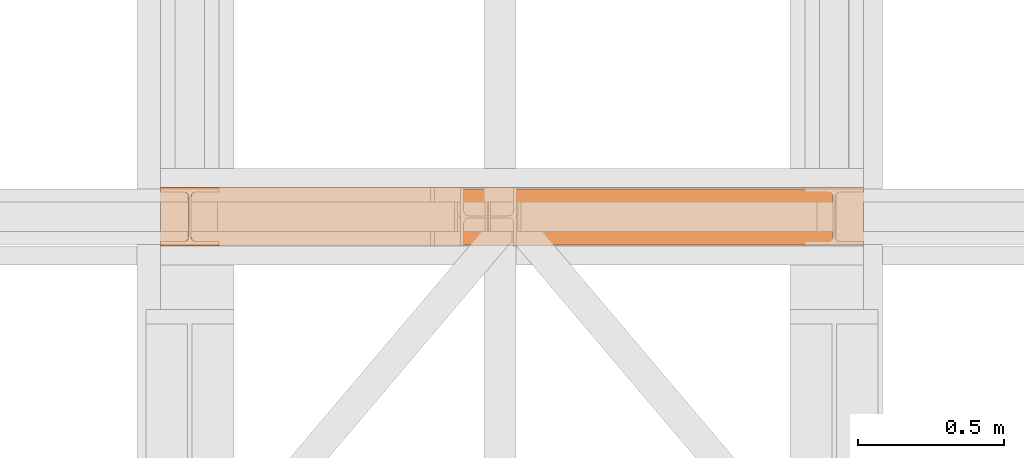
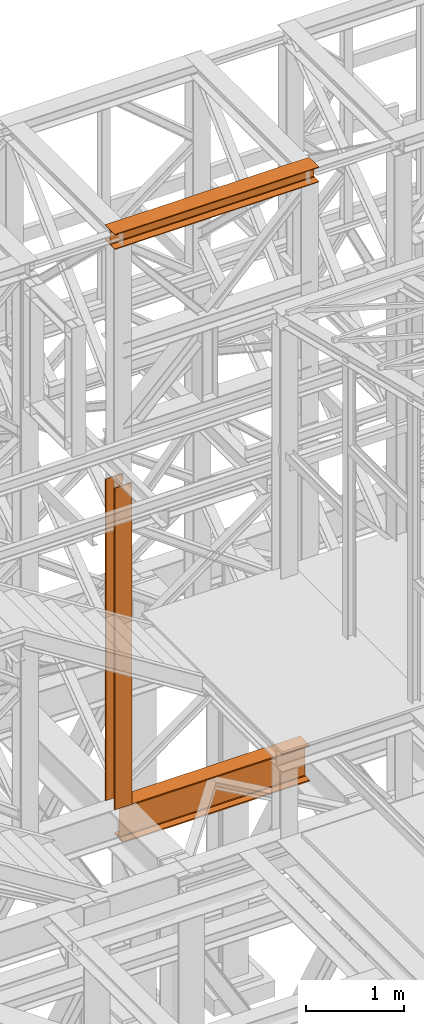
# One storey, part 108 of 208: 3 proxies.
"""IFC2X3 building model written with IfcOpenShell, lengths in millimetres."""

from ifc_helpers import new_model, entity, si_unit, converted_unit, frame, origin, origin_with_axes, place, context, subcontext, project, spatial, faceted_brep, element, save


model = new_model("IFC2X3")

# Units and contexts
model_context = context("Model", 3, precision=1e-05, world=origin())
plan_context = context("Plan", 3, precision=1e-05, world=origin())
body_context = subcontext(model_context, "Body", "Model", "MODEL_VIEW")
ifc_project = project(units=[si_unit("LENGTHUNIT", "METRE", prefix="MILLI"), converted_unit("PLANEANGLEUNIT", "DEGREE", entity("IfcPlaneAngleMeasure", 0.0174532925199433), si_unit("PLANEANGLEUNIT", "RADIAN"), dimensions=[0, 0, 0, 0, 0, 0, 0]), si_unit("AREAUNIT", "SQUARE_METRE"), si_unit("VOLUMEUNIT", "CUBIC_METRE")], contexts=[model_context, plan_context])

# Building, storey
building_placement = place(None, origin())
building = spatial("IfcBuilding", under=ifc_project, at=building_placement, CompositionType="COMPLEX")
storey_placement = place(building_placement, origin_with_axes())
storey = spatial("IfcBuildingStorey", under=building, at=storey_placement, Name="Geschoss", CompositionType="ELEMENT")

# Proxies
proxy_1_placement = place(storey_placement, frame((-0.7450314191753478, -16057.57439657637, 4834.989987483023), z_axis=(0.0, 0.0, 1.0), x_axis=(1.0, 0.0, 0.0)))
element("IfcBuildingElementProxy", 1, at=proxy_1_placement, inside=storey, context=body_context, shape_type="Brep", body=[
    faceted_brep([(2188.009999895692, 0.01000000000021828, 450.0100178813937), (2188.009999895692, 190.0100125169756, 450.0100178813937), (2188.009999895692, 190.0100125169756, 435.4100240564349), (2188.009999895692, 120.7100073045494, 435.4100091552737), (2188.009999895692, 109.841562265754, 433.2347078418734), (2188.009999895692, 101.8853126263621, 425.2784563398363), (2188.009999895692, 99.71000619068764, 414.4100113010409), (2188.009999895692, 99.71000619068764, 35.60999167919181), (2188.009999895692, 101.8853126263621, 24.74154664039634), (2188.009999895692, 109.841562265754, 16.78529513835929), (2188.009999895692, 120.7100073045494, 14.60999382495902), (2188.009999895692, 190.0100125169756, 14.60999382495902), (2188.009999895692, 190.0100125169756, 0.01000000000021828), (2188.009999895692, 0.01000000000021828, 0.01000000000021828), (2188.009999895692, 0.01000000000021828, 14.60999382495902), (2188.009999895692, 69.3100052124264, 14.60999382495902), (2188.009999895692, 80.17845025122188, 16.78529513835929), (2188.009999895692, 88.13469989061377, 24.74154664039634), (2188.009999895692, 90.3100063262882, 35.60999167919181), (2188.009999895692, 90.3100063262882, 414.4100113010409), (2188.009999895692, 88.13469989061377, 425.2784563398363), (2188.009999895692, 80.17845025122188, 433.2347078418734), (2188.009999895692, 69.3100052124264, 435.4100091552737), (2188.009999895692, 0.01000000000021828, 435.4100240564349), (2188.009999895692, 190.0100125169756, 450.0100178813937), (2188.009999895692, 0.01000000000021828, 450.0100178813937), (0.009999999999990905, 0.01000000000021828, 450.0100178813937), (0.009999999999990905, 190.0100125169756, 450.0100178813937), (2188.009999895692, 190.0100125169756, 435.4100240564349), (2188.009999895692, 190.0100125169756, 450.0100178813937), (0.009999999999990905, 190.0100125169756, 450.0100178813937), (0.009999999999990905, 190.0100125169756, 435.4100240564349), (2188.009999895692, 120.7100073045494, 435.4100091552737), (2188.009999895692, 190.0100125169756, 435.4100240564349), (0.009999999999990905, 190.0100125169756, 435.4100240564349), (0.009999999999990905, 120.7100073045494, 435.4100091552737), (2188.009999895692, 109.841562265754, 433.2347078418734), (2188.009999895692, 120.7100073045494, 435.4100091552737), (0.009999999999990905, 120.7100073045494, 435.4100091552737), (0.009999999999990905, 109.841562265754, 433.2347078418734), (2188.009999895692, 101.8853126263621, 425.2784563398363), (2188.009999895692, 109.841562265754, 433.2347078418734), (0.009999999999990905, 109.841562265754, 433.2347078418734), (0.009999999999990905, 101.8853126263621, 425.2784563398363), (2188.009999895692, 99.71000619068764, 414.4100113010409), (2188.009999895692, 101.8853126263621, 425.2784563398363), (0.009999999999990905, 101.8853126263621, 425.2784563398363), (0.009999999999990905, 99.71000619068764, 414.4100113010409), (2188.009999895692, 99.71000619068764, 35.60999167919181), (2188.009999895692, 99.71000619068764, 414.4100113010409), (0.009999999999990905, 99.71000619068764, 414.4100113010409), (0.009999999999990905, 99.71000619068764, 35.60999167919181), (2188.009999895692, 101.8853126263621, 24.74154664039634), (2188.009999895692, 99.71000619068764, 35.60999167919181), (0.009999999999990905, 99.71000619068764, 35.60999167919181), (0.009999999999990905, 101.8853126263621, 24.74154664039634), (2188.009999895692, 109.841562265754, 16.78529513835929), (2188.009999895692, 101.8853126263621, 24.74154664039634), (0.009999999999990905, 101.8853126263621, 24.74154664039634), (0.009999999999990905, 109.841562265754, 16.78529513835929), (2188.009999895692, 120.7100073045494, 14.60999382495902), (2188.009999895692, 109.841562265754, 16.78529513835929), (0.009999999999990905, 109.841562265754, 16.78529513835929), (0.009999999999990905, 120.7100073045494, 14.60999382495902), (2188.009999895692, 190.0100125169756, 14.60999382495902), (2188.009999895692, 120.7100073045494, 14.60999382495902), (0.009999999999990905, 120.7100073045494, 14.60999382495902), (0.009999999999990905, 190.0100125169756, 14.60999382495902), (2188.009999895692, 190.0100125169756, 0.01000000000021828), (2188.009999895692, 190.0100125169756, 14.60999382495902), (0.009999999999990905, 190.0100125169756, 14.60999382495902), (0.009999999999990905, 190.0100125169756, 0.01000000000021828), (2188.009999895692, 0.01000000000021828, 0.01000000000021828), (2188.009999895692, 190.0100125169756, 0.01000000000021828), (0.009999999999990905, 190.0100125169756, 0.01000000000021828), (0.009999999999990905, 0.01000000000021828, 0.01000000000021828), (2188.009999895692, 0.01000000000021828, 14.60999382495902), (2188.009999895692, 0.01000000000021828, 0.01000000000021828), (0.009999999999990905, 0.01000000000021828, 0.01000000000021828), (0.009999999999990905, 0.01000000000021828, 14.60999382495902), (2188.009999895692, 69.3100052124264, 14.60999382495902), (2188.009999895692, 0.01000000000021828, 14.60999382495902), (0.009999999999990905, 0.01000000000021828, 14.60999382495902), (0.009999999999990905, 69.3100052124264, 14.60999382495902), (2188.009999895692, 80.17845025122188, 16.78529513835929), (2188.009999895692, 69.3100052124264, 14.60999382495902), (0.009999999999990905, 69.3100052124264, 14.60999382495902), (0.009999999999990905, 80.17845025122188, 16.78529513835929), (2188.009999895692, 88.13469989061377, 24.74154664039634), (2188.009999895692, 80.17845025122188, 16.78529513835929), (0.009999999999990905, 80.17845025122188, 16.78529513835929), (0.009999999999990905, 88.13469989061377, 24.74154664039634), (2188.009999895692, 90.3100063262882, 35.60999167919181), (2188.009999895692, 88.13469989061377, 24.74154664039634), (0.009999999999990905, 88.13469989061377, 24.74154664039634), (0.009999999999990905, 90.3100063262882, 35.60999167919181), (2188.009999895692, 90.3100063262882, 414.4100113010409), (2188.009999895692, 90.3100063262882, 35.60999167919181), (0.009999999999990905, 90.3100063262882, 35.60999167919181), (0.009999999999990905, 90.3100063262882, 414.4100113010409), (2188.009999895692, 88.13469989061377, 425.2784563398363), (2188.009999895692, 90.3100063262882, 414.4100113010409), (0.009999999999990905, 90.3100063262882, 414.4100113010409), (0.009999999999990905, 88.13469989061377, 425.2784563398363), (2188.009999895692, 80.17845025122188, 433.2347078418734), (2188.009999895692, 88.13469989061377, 425.2784563398363), (0.009999999999990905, 88.13469989061377, 425.2784563398363), (0.009999999999990905, 80.17845025122188, 433.2347078418734), (2188.009999895692, 69.3100052124264, 435.4100091552737), (2188.009999895692, 80.17845025122188, 433.2347078418734), (0.009999999999990905, 80.17845025122188, 433.2347078418734), (0.009999999999990905, 69.3100052124264, 435.4100091552737), (2188.009999895692, 0.01000000000021828, 435.4100240564349), (2188.009999895692, 69.3100052124264, 435.4100091552737), (0.009999999999990905, 69.3100052124264, 435.4100091552737), (0.009999999999990905, 0.01000000000021828, 435.4100240564349), (2188.009999895692, 0.01000000000021828, 450.0100178813937), (2188.009999895692, 0.01000000000021828, 435.4100240564349), (0.009999999999990905, 0.01000000000021828, 435.4100240564349), (0.009999999999990905, 0.01000000000021828, 450.0100178813937), (0.009999999999990905, 0.01000000000021828, 450.0100178813937), (0.009999999999990905, 0.01000000000021828, 435.4100240564349), (0.009999999999990905, 69.3100052124264, 435.4100091552737), (0.009999999999990905, 80.17845025122188, 433.2347078418734), (0.009999999999990905, 88.13469989061377, 425.2784563398363), (0.009999999999990905, 90.3100063262882, 414.4100113010409), (0.009999999999990905, 90.3100063262882, 35.60999167919181), (0.009999999999990905, 88.13469989061377, 24.74154664039634), (0.009999999999990905, 80.17845025122188, 16.78529513835929), (0.009999999999990905, 69.3100052124264, 14.60999382495902), (0.009999999999990905, 0.01000000000021828, 14.60999382495902), (0.009999999999990905, 0.01000000000021828, 0.01000000000021828), (0.009999999999990905, 190.0100125169756, 0.01000000000021828), (0.009999999999990905, 190.0100125169756, 14.60999382495902), (0.009999999999990905, 120.7100073045494, 14.60999382495902), (0.009999999999990905, 109.841562265754, 16.78529513835929), (0.009999999999990905, 101.8853126263621, 24.74154664039634), (0.009999999999990905, 99.71000619068764, 35.60999167919181), (0.009999999999990905, 99.71000619068764, 414.4100113010409), (0.009999999999990905, 101.8853126263621, 425.2784563398363), (0.009999999999990905, 109.841562265754, 433.2347078418734), (0.009999999999990905, 120.7100073045494, 435.4100091552737), (0.009999999999990905, 190.0100125169756, 435.4100240564349), (0.009999999999990905, 190.0100125169756, 450.0100178813937)], [[[0, 1, 2, 3, 4, 5, 6, 7, 8, 9, 10, 11, 12, 13, 14, 15, 16, 17, 18, 19, 20, 21, 22, 23]], [[24, 25, 26, 27]], [[28, 29, 30, 31]], [[32, 33, 34, 35]], [[36, 37, 38, 39]], [[40, 41, 42, 43]], [[44, 45, 46, 47]], [[48, 49, 50, 51]], [[52, 53, 54, 55]], [[56, 57, 58, 59]], [[60, 61, 62, 63]], [[64, 65, 66, 67]], [[68, 69, 70, 71]], [[72, 73, 74, 75]], [[76, 77, 78, 79]], [[80, 81, 82, 83]], [[84, 85, 86, 87]], [[88, 89, 90, 91]], [[92, 93, 94, 95]], [[96, 97, 98, 99]], [[100, 101, 102, 103]], [[104, 105, 106, 107]], [[108, 109, 110, 111]], [[112, 113, 114, 115]], [[116, 117, 118, 119]], [[120, 121, 122, 123, 124, 125, 126, 127, 128, 129, 130, 131, 132, 133, 134, 135, 136, 137, 138, 139, 140, 141, 142, 143]]], orient=[[False], [False], [False], [False], [False], [False], [False], [False], [False], [False], [False], [False], [False], [False], [False], [False], [False], [False], [False], [False], [False], [False], [False], [False], [False], [False]]),
])
proxy_2_placement = place(storey_placement, frame((-106.745032961451, -16062.574391808, 12249.99005869381), z_axis=(0.0, 0.0, 1.0), x_axis=(1.0, 0.0, 0.0)))
element("IfcBuildingElementProxy", 2, at=proxy_2_placement, inside=storey, context=body_context, shape_type="Brep", body=[
    faceted_brep([(0.009999999999990905, 0.01000000000021828, 0.01000000000021828), (0.009999999999990905, 200.0100029802325, 0.01000000000021828), (0.009999999999990905, 200.0100029802325, 10.00999791383765), (0.009999999999990905, 121.2600035762789, 10.01000536441825), (0.009999999999990905, 111.9441915473344, 11.87455041170142), (0.009999999999990905, 105.1245498640838, 18.69419349193595), (0.009999999999990905, 103.2600015571716, 28.01000458955787), (0.009999999999990905, 103.2600015571716, 162.0100153779986), (0.009999999999990905, 105.1245498640838, 171.3258264756205), (0.009999999999990905, 111.9441915473344, 178.145469555855), (0.009999999999990905, 121.2600035762789, 180.0100146031382), (0.009999999999990905, 200.0100029802325, 180.0100146031382), (0.009999999999990905, 200.0100029802325, 190.0100125169756), (0.009999999999990905, 0.01000000000021828, 190.0100125169756), (0.009999999999990905, 0.01000000000021828, 180.0100146031382), (0.009999999999990905, 78.75999940395377, 180.0100146031382), (0.009999999999990905, 88.07581143289826, 178.145469555855), (0.009999999999990905, 94.89545311614893, 171.3258264756205), (0.009999999999990905, 96.76000142306111, 162.0100153779986), (0.009999999999990905, 96.76000142306111, 28.01000458955787), (0.009999999999990905, 94.89545311614893, 18.69419349193595), (0.009999999999990905, 88.07581143289826, 11.87455041170142), (0.009999999999990905, 78.75999940395377, 10.01000536441825), (0.009999999999990905, 0.01000000000021828, 10.00999791383765), (0.009999999999990905, 200.0100029802325, 0.01000000000021828), (0.009999999999990905, 0.01000000000021828, 0.01000000000021828), (2400.010002980233, 0.01000000000021828, 0.01000000000021828), (2400.010002980233, 200.0100029802325, 0.01000000000021828), (0.009999999999990905, 200.0100029802325, 10.00999791383765), (0.009999999999990905, 200.0100029802325, 0.01000000000021828), (2400.010002980233, 200.0100029802325, 0.01000000000021828), (2400.010002980233, 200.0100029802325, 10.00999791383765), (0.009999999999990905, 121.2600035762789, 10.01000536441825), (0.009999999999990905, 200.0100029802325, 10.00999791383765), (2400.010002980233, 200.0100029802325, 10.00999791383765), (2400.010002980233, 121.2600035762789, 10.01000536441825), (0.009999999999990905, 111.9441915473344, 11.87455041170142), (0.009999999999990905, 121.2600035762789, 10.01000536441825), (2400.010002980233, 121.2600035762789, 10.01000536441825), (2400.010002980233, 111.9441915473344, 11.87455041170142), (0.009999999999990905, 105.1245498640838, 18.69419349193595), (0.009999999999990905, 111.9441915473344, 11.87455041170142), (2400.010002980233, 111.9441915473344, 11.87455041170142), (2400.010002980233, 105.1245498640838, 18.69419349193595), (0.009999999999990905, 103.2600015571716, 28.01000458955787), (0.009999999999990905, 105.1245498640838, 18.69419349193595), (2400.010002980233, 105.1245498640838, 18.69419349193595), (2400.010002980233, 103.2600015571716, 28.01000458955787), (0.009999999999990905, 103.2600015571716, 162.0100153779986), (0.009999999999990905, 103.2600015571716, 28.01000458955787), (2400.010002980233, 103.2600015571716, 28.01000458955787), (2400.010002980233, 103.2600015571716, 162.0100153779986), (0.009999999999990905, 105.1245498640838, 171.3258264756205), (0.009999999999990905, 103.2600015571716, 162.0100153779986), (2400.010002980233, 103.2600015571716, 162.0100153779986), (2400.010002980233, 105.1245498640838, 171.3258264756205), (0.009999999999990905, 111.9441915473344, 178.145469555855), (0.009999999999990905, 105.1245498640838, 171.3258264756205), (2400.010002980233, 105.1245498640838, 171.3258264756205), (2400.010002980233, 111.9441915473344, 178.145469555855), (0.009999999999990905, 121.2600035762789, 180.0100146031382), (0.009999999999990905, 111.9441915473344, 178.145469555855), (2400.010002980233, 111.9441915473344, 178.145469555855), (2400.010002980233, 121.2600035762789, 180.0100146031382), (0.009999999999990905, 200.0100029802325, 180.0100146031382), (0.009999999999990905, 121.2600035762789, 180.0100146031382), (2400.010002980233, 121.2600035762789, 180.0100146031382), (2400.010002980233, 200.0100029802325, 180.0100146031382), (0.009999999999990905, 200.0100029802325, 190.0100125169756), (0.009999999999990905, 200.0100029802325, 180.0100146031382), (2400.010002980233, 200.0100029802325, 180.0100146031382), (2400.010002980233, 200.0100029802325, 190.0100125169756), (0.009999999999990905, 0.01000000000021828, 190.0100125169756), (0.009999999999990905, 200.0100029802325, 190.0100125169756), (2400.010002980233, 200.0100029802325, 190.0100125169756), (2400.010002980233, 0.01000000000021828, 190.0100125169756), (0.009999999999990905, 0.01000000000021828, 180.0100146031382), (0.009999999999990905, 0.01000000000021828, 190.0100125169756), (2400.010002980233, 0.01000000000021828, 190.0100125169756), (2400.010002980233, 0.01000000000021828, 180.0100146031382), (0.009999999999990905, 78.75999940395377, 180.0100146031382), (0.009999999999990905, 0.01000000000021828, 180.0100146031382), (2400.010002980233, 0.01000000000021828, 180.0100146031382), (2400.010002980233, 78.75999940395377, 180.0100146031382), (0.009999999999990905, 88.07581143289826, 178.145469555855), (0.009999999999990905, 78.75999940395377, 180.0100146031382), (2400.010002980233, 78.75999940395377, 180.0100146031382), (2400.010002980233, 88.07581143289826, 178.145469555855), (0.009999999999990905, 94.89545311614893, 171.3258264756205), (0.009999999999990905, 88.07581143289826, 178.145469555855), (2400.010002980233, 88.07581143289826, 178.145469555855), (2400.010002980233, 94.89545311614893, 171.3258264756205), (0.009999999999990905, 96.76000142306111, 162.0100153779986), (0.009999999999990905, 94.89545311614893, 171.3258264756205), (2400.010002980233, 94.89545311614893, 171.3258264756205), (2400.010002980233, 96.76000142306111, 162.0100153779986), (0.009999999999990905, 96.76000142306111, 28.01000458955787), (0.009999999999990905, 96.76000142306111, 162.0100153779986), (2400.010002980233, 96.76000142306111, 162.0100153779986), (2400.010002980233, 96.76000142306111, 28.01000458955787), (0.009999999999990905, 94.89545311614893, 18.69419349193595), (0.009999999999990905, 96.76000142306111, 28.01000458955787), (2400.010002980233, 96.76000142306111, 28.01000458955787), (2400.010002980233, 94.89545311614893, 18.69419349193595), (0.009999999999990905, 88.07581143289826, 11.87455041170142), (0.009999999999990905, 94.89545311614893, 18.69419349193595), (2400.010002980233, 94.89545311614893, 18.69419349193595), (2400.010002980233, 88.07581143289826, 11.87455041170142), (0.009999999999990905, 78.75999940395377, 10.01000536441825), (0.009999999999990905, 88.07581143289826, 11.87455041170142), (2400.010002980233, 88.07581143289826, 11.87455041170142), (2400.010002980233, 78.75999940395377, 10.01000536441825), (0.009999999999990905, 0.01000000000021828, 10.00999791383765), (0.009999999999990905, 78.75999940395377, 10.01000536441825), (2400.010002980233, 78.75999940395377, 10.01000536441825), (2400.010002980233, 0.01000000000021828, 10.00999791383765), (0.009999999999990905, 0.01000000000021828, 0.01000000000021828), (0.009999999999990905, 0.01000000000021828, 10.00999791383765), (2400.010002980233, 0.01000000000021828, 10.00999791383765), (2400.010002980233, 0.01000000000021828, 0.01000000000021828), (2400.010002980233, 0.01000000000021828, 0.01000000000021828), (2400.010002980233, 0.01000000000021828, 10.00999791383765), (2400.010002980233, 78.75999940395377, 10.01000536441825), (2400.010002980233, 88.07581143289826, 11.87455041170142), (2400.010002980233, 94.89545311614893, 18.69419349193595), (2400.010002980233, 96.76000142306111, 28.01000458955787), (2400.010002980233, 96.76000142306111, 162.0100153779986), (2400.010002980233, 94.89545311614893, 171.3258264756205), (2400.010002980233, 88.07581143289826, 178.145469555855), (2400.010002980233, 78.75999940395377, 180.0100146031382), (2400.010002980233, 0.01000000000021828, 180.0100146031382), (2400.010002980233, 0.01000000000021828, 190.0100125169756), (2400.010002980233, 200.0100029802325, 190.0100125169756), (2400.010002980233, 200.0100029802325, 180.0100146031382), (2400.010002980233, 121.2600035762789, 180.0100146031382), (2400.010002980233, 111.9441915473344, 178.145469555855), (2400.010002980233, 105.1245498640838, 171.3258264756205), (2400.010002980233, 103.2600015571716, 162.0100153779986), (2400.010002980233, 103.2600015571716, 28.01000458955787), (2400.010002980233, 105.1245498640838, 18.69419349193595), (2400.010002980233, 111.9441915473344, 11.87455041170142), (2400.010002980233, 121.2600035762789, 10.01000536441825), (2400.010002980233, 200.0100029802325, 10.00999791383765), (2400.010002980233, 200.0100029802325, 0.01000000000021828)], [[[0, 1, 2, 3, 4, 5, 6, 7, 8, 9, 10, 11, 12, 13, 14, 15, 16, 17, 18, 19, 20, 21, 22, 23]], [[24, 25, 26, 27]], [[28, 29, 30, 31]], [[32, 33, 34, 35]], [[36, 37, 38, 39]], [[40, 41, 42, 43]], [[44, 45, 46, 47]], [[48, 49, 50, 51]], [[52, 53, 54, 55]], [[56, 57, 58, 59]], [[60, 61, 62, 63]], [[64, 65, 66, 67]], [[68, 69, 70, 71]], [[72, 73, 74, 75]], [[76, 77, 78, 79]], [[80, 81, 82, 83]], [[84, 85, 86, 87]], [[88, 89, 90, 91]], [[92, 93, 94, 95]], [[96, 97, 98, 99]], [[100, 101, 102, 103]], [[104, 105, 106, 107]], [[108, 109, 110, 111]], [[112, 113, 114, 115]], [[116, 117, 118, 119]], [[120, 121, 122, 123, 124, 125, 126, 127, 128, 129, 130, 131, 132, 133, 134, 135, 136, 137, 138, 139, 140, 141, 142, 143]]], orient=[[False], [False], [False], [False], [False], [False], [False], [False], [False], [False], [False], [False], [False], [False], [False], [False], [False], [False], [False], [False], [False], [False], [False], [False], [False], [False]]),
])
proxy_3_placement = place(storey_placement, frame((-106.7450299812169, -16062.57439031789, 5284.990005364414), z_axis=(0.0, 0.0, 1.0), x_axis=(1.0, 0.0, 0.0)))
element("IfcBuildingElementProxy", 3, at=proxy_3_placement, inside=storey, Name="3D Element", context=body_context, shape_type="Brep", body=[
    faceted_brep([(0.01000000000000512, 15.01000000000022, 0.01000000000021828), (0.01000000000000512, 0.01000000000021828, 0.01000000000021828), (200.01, 0.01000000000021828, 0.01000000000021828), (200.01, 15.01000000000022, 0.01000000000021828), (122.51, 15.01000000000022, 0.01000000000021828), (116.9477129694262, 15.8910440384916, 0.01000000000021828), (111.9298832894654, 18.44771635773031, 0.01000000000021828), (107.9477163577319, 22.42988328946558, 0.01000000000021828), (105.3910440384932, 27.44771296942599, 0.01000000000021828), (104.51, 33.01000000000022, 0.01000000000021828), (104.51, 167.0100000000002, 0.01000000000021828), (105.6055874411056, 172.9933586889038, 0.01000000000021828), (107.9477163577319, 177.5901167105349, 0.01000000000021828), (111.9298832894654, 181.5722836422665, 0.01000000000021828), (116.9477129694262, 184.1289559615052, 0.01000000000021828), (122.51, 185.0100000000002, 0.01000000000021828), (200.01, 185.0100000000002, 0.01000000000021828), (200.01, 200.0100000000002, 0.01000000000021828), (0.01000000000000512, 200.0100000000002, 0.01000000000021828), (0.01000000000000512, 185.0100000000002, 0.01000000000021828), (77.51, 185.0100000000002, 0.01000000000021828), (83.07228703057332, 184.1289559615052, 0.01000000000021828), (88.09011671053419, 181.5722836422665, 0.01000000000021828), (92.07228364226764, 177.5901167105349, 0.01000000000021828), (94.62895596150635, 172.5722870305744, 0.01000000000021828), (95.51, 167.0100000000002, 0.01000000000021828), (95.51, 33.01000000000022, 0.01000000000021828), (94.62895596150635, 27.44771296942599, 0.01000000000021828), (92.07228364226764, 22.42988328946558, 0.01000000000021828), (88.09011671053419, 18.44771635773031, 0.01000000000021828), (83.07228703057332, 15.8910440384916, 0.01000000000021828), (77.51, 15.01000000000022, 0.01000000000021828), (0.01000000000000512, 0.01000000000021828, 0.01000000000021828), (0.01000000000000512, 15.01000000000022, 0.01000000000021828), (0.01000000000000512, 15.01000000000022, 4000.01), (0.01000000000000512, 0.01000000000021828, 4000.01), (200.01, 0.01000000000021828, 0.01000000000021828), (0.01000000000000512, 0.01000000000021828, 0.01000000000021828), (0.01000000000000512, 0.01000000000021828, 4000.01), (200.01, 0.01000000000021828, 4000.01), (200.01, 15.01000000000022, 0.01000000000021828), (200.01, 0.01000000000021828, 0.01000000000021828), (200.01, 0.01000000000021828, 4000.01), (200.01, 15.01000000000022, 4000.01), (122.51, 15.01000000000022, 0.01000000000021828), (200.01, 15.01000000000022, 0.01000000000021828), (200.01, 15.01000000000022, 4000.01), (122.51, 15.01000000000022, 4000.01), (116.9477129694262, 15.8910440384916, 0.01000000000021828), (122.51, 15.01000000000022, 0.01000000000021828), (122.51, 15.01000000000022, 4000.01), (116.9477129694262, 15.8910440384916, 4000.01), (111.9298832894654, 18.44771635773031, 0.01000000000021828), (116.9477129694262, 15.8910440384916, 0.01000000000021828), (116.9477129694262, 15.8910440384916, 4000.01), (111.9298832894654, 18.44771635773031, 4000.01), (107.9477163577319, 22.42988328946558, 0.01000000000021828), (111.9298832894654, 18.44771635773031, 0.01000000000021828), (111.9298832894654, 18.44771635773031, 4000.01), (107.9477163577319, 22.42988328946558, 4000.01), (105.3910440384932, 27.44771296942599, 0.01000000000021828), (107.9477163577319, 22.42988328946558, 0.01000000000021828), (107.9477163577319, 22.42988328946558, 4000.01), (105.3910440384932, 27.44771296942599, 4000.01), (104.51, 33.01000000000022, 0.01000000000021828), (105.3910440384932, 27.44771296942599, 0.01000000000021828), (105.3910440384932, 27.44771296942599, 4000.01), (104.51, 33.01000000000022, 4000.01), (104.51, 167.0100000000002, 0.01000000000021828), (104.51, 33.01000000000022, 0.01000000000021828), (104.51, 33.01000000000022, 4000.01), (104.51, 167.0100000000002, 4000.01), (105.6055874411056, 172.9933586889038, 0.01000000000021828), (104.51, 167.0100000000002, 0.01000000000021828), (104.51, 167.0100000000002, 4000.01), (105.6055874411056, 172.9933586889038, 4000.01), (107.9477163577319, 177.5901167105349, 0.01000000000021828), (105.6055874411056, 172.9933586889038, 0.01000000000021828), (105.6055874411056, 172.9933586889038, 4000.01), (107.9477163577319, 177.5901167105349, 4000.01), (111.9298832894654, 181.5722836422665, 0.01000000000021828), (107.9477163577319, 177.5901167105349, 0.01000000000021828), (107.9477163577319, 177.5901167105349, 4000.01), (111.9298832894654, 181.5722836422665, 4000.01), (116.9477129694262, 184.1289559615052, 0.01000000000021828), (111.9298832894654, 181.5722836422665, 0.01000000000021828), (111.9298832894654, 181.5722836422665, 4000.01), (116.9477129694262, 184.1289559615052, 4000.01), (122.51, 185.0100000000002, 0.01000000000021828), (116.9477129694262, 184.1289559615052, 0.01000000000021828), (116.9477129694262, 184.1289559615052, 4000.01), (122.51, 185.0100000000002, 4000.01), (200.01, 185.0100000000002, 0.01000000000021828), (122.51, 185.0100000000002, 0.01000000000021828), (122.51, 185.0100000000002, 4000.01), (200.01, 185.0100000000002, 4000.01), (200.01, 200.0100000000002, 0.01000000000021828), (200.01, 185.0100000000002, 0.01000000000021828), (200.01, 185.0100000000002, 4000.01), (200.01, 200.0100000000002, 4000.01), (0.01000000000000512, 200.0100000000002, 0.01000000000021828), (200.01, 200.0100000000002, 0.01000000000021828), (200.01, 200.0100000000002, 4000.01), (0.01000000000000512, 200.0100000000002, 4000.01), (0.01000000000000512, 185.0100000000002, 0.01000000000021828), (0.01000000000000512, 200.0100000000002, 0.01000000000021828), (0.01000000000000512, 200.0100000000002, 4000.01), (0.01000000000000512, 185.0100000000002, 4000.01), (77.51, 185.0100000000002, 0.01000000000021828), (0.01000000000000512, 185.0100000000002, 0.01000000000021828), (0.01000000000000512, 185.0100000000002, 4000.01), (77.51, 185.0100000000002, 4000.01), (83.07228703057332, 184.1289559615052, 0.01000000000021828), (77.51, 185.0100000000002, 0.01000000000021828), (77.51, 185.0100000000002, 4000.01), (83.07228703057332, 184.1289559615052, 4000.01), (88.09011671053419, 181.5722836422665, 0.01000000000021828), (83.07228703057332, 184.1289559615052, 0.01000000000021828), (83.07228703057332, 184.1289559615052, 4000.01), (88.09011671053419, 181.5722836422665, 4000.01), (92.07228364226764, 177.5901167105349, 0.01000000000021828), (88.09011671053419, 181.5722836422665, 0.01000000000021828), (88.09011671053419, 181.5722836422665, 4000.01), (92.07228364226764, 177.5901167105349, 4000.01), (94.62895596150635, 172.5722870305744, 0.01000000000021828), (92.07228364226764, 177.5901167105349, 0.01000000000021828), (92.07228364226764, 177.5901167105349, 4000.01), (94.62895596150635, 172.5722870305744, 4000.01), (95.51, 167.0100000000002, 0.01000000000021828), (94.62895596150635, 172.5722870305744, 0.01000000000021828), (94.62895596150635, 172.5722870305744, 4000.01), (95.51, 167.0100000000002, 4000.01), (95.51, 33.01000000000022, 0.01000000000021828), (95.51, 167.0100000000002, 0.01000000000021828), (95.51, 167.0100000000002, 4000.01), (95.51, 33.01000000000022, 4000.01), (94.62895596150635, 27.44771296942599, 0.01000000000021828), (95.51, 33.01000000000022, 0.01000000000021828), (95.51, 33.01000000000022, 4000.01), (94.62895596150635, 27.44771296942599, 4000.01), (92.07228364226764, 22.42988328946558, 0.01000000000021828), (94.62895596150635, 27.44771296942599, 0.01000000000021828), (94.62895596150635, 27.44771296942599, 4000.01), (92.07228364226764, 22.42988328946558, 4000.01), (88.09011671053419, 18.44771635773031, 0.01000000000021828), (92.07228364226764, 22.42988328946558, 0.01000000000021828), (92.07228364226764, 22.42988328946558, 4000.01), (88.09011671053419, 18.44771635773031, 4000.01), (83.07228703057332, 15.8910440384916, 0.01000000000021828), (88.09011671053419, 18.44771635773031, 0.01000000000021828), (88.09011671053419, 18.44771635773031, 4000.01), (83.07228703057332, 15.8910440384916, 4000.01), (77.51, 15.01000000000022, 0.01000000000021828), (83.07228703057332, 15.8910440384916, 0.01000000000021828), (83.07228703057332, 15.8910440384916, 4000.01), (77.51, 15.01000000000022, 4000.01), (0.01000000000000512, 15.01000000000022, 0.01000000000021828), (77.51, 15.01000000000022, 0.01000000000021828), (77.51, 15.01000000000022, 4000.01), (0.01000000000000512, 15.01000000000022, 4000.01), (0.01000000000000512, 15.01000000000022, 4000.01), (77.51, 15.01000000000022, 4000.01), (83.07228703057332, 15.8910440384916, 4000.01), (88.09011671053419, 18.44771635773031, 4000.01), (92.07228364226764, 22.42988328946558, 4000.01), (94.62895596150635, 27.44771296942599, 4000.01), (95.51, 33.01000000000022, 4000.01), (95.51, 167.0100000000002, 4000.01), (94.62895596150635, 172.5722870305744, 4000.01), (92.07228364226764, 177.5901167105349, 4000.01), (88.09011671053419, 181.5722836422665, 4000.01), (83.07228703057332, 184.1289559615052, 4000.01), (77.51, 185.0100000000002, 4000.01), (0.01000000000000512, 185.0100000000002, 4000.01), (0.01000000000000512, 200.0100000000002, 4000.01), (200.01, 200.0100000000002, 4000.01), (200.01, 185.0100000000002, 4000.01), (122.51, 185.0100000000002, 4000.01), (116.9477129694262, 184.1289559615052, 4000.01), (111.9298832894654, 181.5722836422665, 4000.01), (107.9477163577319, 177.5901167105349, 4000.01), (105.6055874411056, 172.9933586889038, 4000.01), (104.51, 167.0100000000002, 4000.01), (104.51, 33.01000000000022, 4000.01), (105.3910440384932, 27.44771296942599, 4000.01), (107.9477163577319, 22.42988328946558, 4000.01), (111.9298832894654, 18.44771635773031, 4000.01), (116.9477129694262, 15.8910440384916, 4000.01), (122.51, 15.01000000000022, 4000.01), (200.01, 15.01000000000022, 4000.01), (200.01, 0.01000000000021828, 4000.01), (0.01000000000000512, 0.01000000000021828, 4000.01)], [[[0, 1, 2, 3, 4, 5, 6, 7, 8, 9, 10, 11, 12, 13, 14, 15, 16, 17, 18, 19, 20, 21, 22, 23, 24, 25, 26, 27, 28, 29, 30, 31]], [[32, 33, 34, 35]], [[36, 37, 38, 39]], [[40, 41, 42, 43]], [[44, 45, 46, 47]], [[48, 49, 50, 51]], [[52, 53, 54, 55]], [[56, 57, 58, 59]], [[60, 61, 62, 63]], [[64, 65, 66, 67]], [[68, 69, 70, 71]], [[72, 73, 74, 75]], [[76, 77, 78, 79]], [[80, 81, 82, 83]], [[84, 85, 86, 87]], [[88, 89, 90, 91]], [[92, 93, 94, 95]], [[96, 97, 98, 99]], [[100, 101, 102, 103]], [[104, 105, 106, 107]], [[108, 109, 110, 111]], [[112, 113, 114, 115]], [[116, 117, 118, 119]], [[120, 121, 122, 123]], [[124, 125, 126, 127]], [[128, 129, 130, 131]], [[132, 133, 134, 135]], [[136, 137, 138, 139]], [[140, 141, 142, 143]], [[144, 145, 146, 147]], [[148, 149, 150, 151]], [[152, 153, 154, 155]], [[156, 157, 158, 159]], [[160, 161, 162, 163, 164, 165, 166, 167, 168, 169, 170, 171, 172, 173, 174, 175, 176, 177, 178, 179, 180, 181, 182, 183, 184, 185, 186, 187, 188, 189, 190, 191]]], orient=[[False], [False], [False], [False], [False], [False], [False], [False], [False], [False], [False], [False], [False], [False], [False], [False], [False], [False], [False], [False], [False], [False], [False], [False], [False], [False], [False], [False], [False], [False], [False], [False], [False], [False]]),
])

save(model, "model.ifc")
